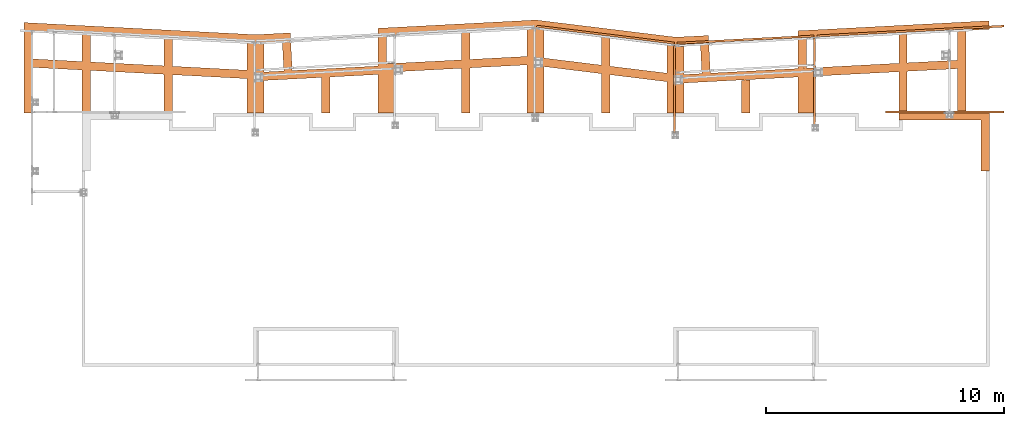
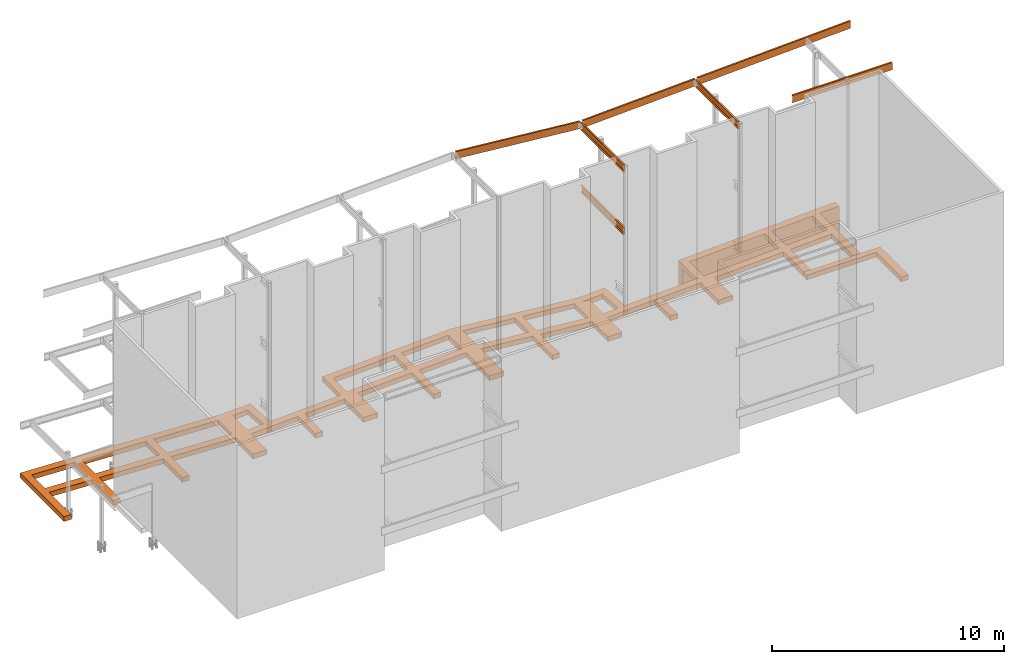
# One storey, part 4 of 89: 9 proxies.
"""IFC4 building model written with IfcOpenShell, lengths in feet."""

from ifc_helpers import new_model, entity, si_unit, converted_unit, derived_unit, direction, frame, frame_2d, origin, origin_2d_with_axis, place, context, subcontext, project, spatial, polyline, rectangle, outline, extrude, source, transform, mapped, material, type_object, type_shapes, element, save


model = new_model("IFC4")

# Units and contexts
model_context = context("Model", 3, precision=0.0001, world=origin(), true_north=direction((6.12303176911189e-17, 1.0)))
body_context = subcontext(model_context, "Body", "Model", "MODEL_VIEW")
ifc_project = project(units=[converted_unit("LENGTHUNIT", "FOOT", entity("IfcRatioMeasure", 0.3048), si_unit("LENGTHUNIT", "METRE"), dimensions=[1, 0, 0, 0, 0, 0, 0]), converted_unit("AREAUNIT", "SQUARE FOOT", entity("IfcRatioMeasure", 0.09290304), si_unit("AREAUNIT", "SQUARE_METRE"), dimensions=[2, 0, 0, 0, 0, 0, 0]), converted_unit("VOLUMEUNIT", "CUBIC FOOT", entity("IfcRatioMeasure", 0.028316846592), si_unit("VOLUMEUNIT", "CUBIC_METRE"), dimensions=[3, 0, 0, 0, 0, 0, 0]), si_unit("PLANEANGLEUNIT", "RADIAN"), si_unit("MASSUNIT", "GRAM", prefix="KILO"), derived_unit("MASSDENSITYUNIT", [(si_unit("MASSUNIT", "GRAM", prefix="KILO"), 1), (si_unit("LENGTHUNIT", "METRE"), -3)]), derived_unit("MOMENTOFINERTIAUNIT", [(si_unit("LENGTHUNIT", "METRE"), 4)]), si_unit("TIMEUNIT", "SECOND"), si_unit("FREQUENCYUNIT", "HERTZ"), si_unit("THERMODYNAMICTEMPERATUREUNIT", "DEGREE_CELSIUS"), derived_unit("THERMALTRANSMITTANCEUNIT", [(si_unit("MASSUNIT", "GRAM", prefix="KILO"), 1), (si_unit("THERMODYNAMICTEMPERATUREUNIT", "KELVIN"), -1), (si_unit("TIMEUNIT", "SECOND"), -3)]), derived_unit("VOLUMETRICFLOWRATEUNIT", [(si_unit("LENGTHUNIT", "METRE"), 3), (si_unit("TIMEUNIT", "SECOND"), -1)]), si_unit("ELECTRICCURRENTUNIT", "AMPERE"), si_unit("ELECTRICVOLTAGEUNIT", "VOLT"), si_unit("POWERUNIT", "WATT"), si_unit("FORCEUNIT", "NEWTON"), si_unit("ILLUMINANCEUNIT", "LUX"), si_unit("LUMINOUSFLUXUNIT", "LUMEN"), si_unit("LUMINOUSINTENSITYUNIT", "CANDELA"), derived_unit("USERDEFINED", [(si_unit("MASSUNIT", "GRAM", prefix="KILO"), -1), (si_unit("LENGTHUNIT", "METRE"), -2), (si_unit("TIMEUNIT", "SECOND"), 3), (si_unit("LUMINOUSFLUXUNIT", "LUMEN"), 1)]), derived_unit("LINEARVELOCITYUNIT", [(si_unit("LENGTHUNIT", "METRE"), 1), (si_unit("TIMEUNIT", "SECOND"), -1)]), si_unit("PRESSUREUNIT", "PASCAL"), derived_unit("USERDEFINED", [(si_unit("LENGTHUNIT", "METRE"), -2), (si_unit("MASSUNIT", "GRAM", prefix="KILO"), 1), (si_unit("TIMEUNIT", "SECOND"), -2)]), derived_unit("LINEARFORCEUNIT", [(si_unit("MASSUNIT", "GRAM", prefix="KILO"), 1), (si_unit("LENGTHUNIT", "METRE"), 1), (si_unit("TIMEUNIT", "SECOND"), -2), (si_unit("LENGTHUNIT", "METRE"), -1)]), derived_unit("PLANARFORCEUNIT", [(si_unit("MASSUNIT", "GRAM", prefix="KILO"), 1), (si_unit("LENGTHUNIT", "METRE"), 1), (si_unit("TIMEUNIT", "SECOND"), -2), (si_unit("LENGTHUNIT", "METRE"), -2)])], contexts=[model_context])

# Site, building, storey
site_placement = place(None, origin())
site = spatial("IfcSite", under=ifc_project, at=site_placement, CompositionType="ELEMENT")
building_placement = place(site_placement, frame((-472.238160486, -49.138065117, 0.0)))
building = spatial("IfcBuilding", under=site, at=building_placement, CompositionType="ELEMENT")
storey_placement = place(building_placement, origin())
storey = spatial("IfcBuildingStorey", under=building, at=storey_placement, Name="Level 1", CompositionType="ELEMENT", Elevation=0.0)

# Proxies
ifc_material_1 = material(Name="Color", Category="Materials")
building_element_proxy_type_1 = type_object("IfcBuildingElementProxyType", Name="M_21", PredefinedType="NOTDEFINED", material=ifc_material_1)
shared_shape_1 = source(origin(), body_context, "Body", "SweptSolid", [
    extrude(outline(polyline([(3.38888888888886, -5.02777777777771), (4.55555555555554, -5.02777777777771), (4.55555555555554, 2.97222222222229), (-7.94444444444446, 2.97222222222229), (-7.94444444444446, 2.05555555555566), (3.38888888888886, 2.05555555555566), (3.38888888888886, -5.02777777777771)])), frame((7.94444444444446, 5.02777777777771, 0.0)), (0.0, 0.0, 1.0), 0.833333333333333),
])
type_shapes(building_element_proxy_type_1, [shared_shape_1])
proxy_1_placement = place(building_placement, frame((319.309225024729, 1000.0, -0.833333333333333)))
element("IfcBuildingElementProxy", 1, at=proxy_1_placement, inside=storey, type_object=building_element_proxy_type_1, material=ifc_material_1, Name="M_21:M_21", ObjectType="M_21:M_21", PredefinedType="NOTDEFINED", context=body_context, shape_type="MappedRepresentation", body=[
    mapped(shared_shape_1, transform((0.0, 0.0, 0.0), scale=1.0)),
])
building_element_proxy_type_2 = type_object("IfcBuildingElementProxyType", Name="e28", PredefinedType="NOTDEFINED", material=ifc_material_1)
shared_shape_2 = source(origin(), body_context, "Body", "SweptSolid", [
    extrude(outline(polyline([(-0.716220445171256, -2.60390514617306), (0.451947401929668, -2.60390514617306), (0.716269587385031, 2.60487355113727), (-0.451996544143557, 2.60293674120885), (-0.716220445171256, -2.60390514617306)])), frame((107.489256819971, 8.79611654616951, 3.33333333333334), z_axis=(0.0, 0.0, 1.0), x_axis=(0.998714927449883, 0.05068030868863, 0.0)), (0.0, 0.0, 1.0), 0.833333333333333),
    extrude(outline(polyline([(-0.583333333333314, -5.48222303152397), (0.583333333333371, -5.48222303152397), (0.583333333333371, 5.51279423610583), (-0.583333333333314, 5.45165182694211), (-0.583333333333314, -5.48222303152397)])), frame((121.405923486638, 5.48222303152409, 3.33333333333334)), (0.0, 0.0, 1.0), 0.833333333333333),
    extrude(outline(polyline([(-1.16666666666663, -2.52509735193451), (1.16666666666669, -2.52509735193451), (1.16666666666669, 2.58623976109823), (-1.16666666666663, 2.46395494277112), (-1.16666666666663, -2.52509735193451)])), frame((108.072590153305, 2.52509735193462, 3.33333333333334)), (0.0, 0.0, 1.0), 0.833333333333333),
    extrude(outline(polyline([(-0.583333333333371, -2.2767293855203), (0.583333333333314, -2.2767293855203), (0.583333333333314, 2.30730059010205), (-0.583333333333371, 2.24615818093855), (-0.583333333333371, -2.2767293855203)])), frame((99.6666666666675, 2.27672938552041, 3.33333333333334)), (0.0, 0.0, 1.0), 0.833333333333333),
    extrude(outline(polyline([(-1.16666666666663, -4.65859764349), (1.16666666666669, -4.65859764349), (1.16666666666669, 4.51534898910336), (-1.16666666666663, 4.80184629787686), (-1.16666666666663, -4.65859764349)])), frame((90.0, 4.65859764349329, 3.33333333333334)), (0.0, 0.0, 1.0), 0.833333333333333),
    extrude(outline(polyline([(-0.583333333333371, -5.25205635452062), (0.583333333333314, -5.25205635452062), (0.583333333333314, 5.18043202732736), (-0.583333333333371, 5.32368068171388), (-0.583333333333371, -5.25205635452062)])), frame((80.3333333333334, 5.25205635452073, 3.33333333333334)), (0.0, 0.0, 1.0), 0.833333333333333),
    extrude(outline(polyline([(-1.16501369037434, -6.9742324147046), (1.16831964295898, -6.9742324147046), (1.16831964295898, 4.57354906201101), (-0.00661190516927945, 4.71781251623895), (-1.16501369037434, 4.65710325115879), (-1.16501369037434, -6.9742324147046)])), frame((70.6650136903744, 6.97423241470472, 3.33333333333334)), (0.0, 0.0, 1.0), 0.833333333333333),
    extrude(outline(polyline([(-0.583333333333314, -5.59293477097879), (0.583333333333371, -5.59293477097879), (0.583333333333371, 5.62350597556065), (-0.583333333333314, 5.56236356639715), (-0.583333333333314, -5.59293477097879)])), frame((61.0, 5.5929347709789, 3.33333333333334)), (0.0, 0.0, 1.0), 0.833333333333333),
    extrude(outline(polyline([(-1.16666666666666, -2.82430670127235), (1.16666666666669, -2.82430670127235), (1.16666666666669, 2.88544911043596), (-1.16666666666666, 2.76316429210874), (-1.16666666666666, -2.82430670127235)])), frame((50.0833333333338, 2.82430670127246, 3.33333333333334)), (0.0, 0.0, 1.0), 0.833333333333333),
    extrude(outline(polyline([(-0.583333333333343, -2.47858575353951), (0.583333333333343, -2.47858575353951), (0.583333333333343, 2.50915695812125), (-0.583333333333343, 2.44801454895764), (-0.583333333333343, -2.47858575353951)])), frame((41.6666666666672, 2.47858575353962, 3.33333333333334)), (0.0, 0.0, 1.0), 0.833333333333333),
    extrude(outline(polyline([(-0.583333333333314, -5.14977697854977), (0.583333333333343, -5.14977697854977), (0.583333333333343, 5.11920577396768), (-0.583333333333314, 5.1803481831314), (-0.583333333333314, -5.14977697854977)])), frame((19.9166666666674, 5.14977697854988, 3.33333333333334)), (0.0, 0.0, 1.0), 0.833333333333333),
    extrude(outline(polyline([(-0.583333333333314, -5.4467543944869), (0.583333333333343, -5.4467543944869), (0.583333333333343, 5.41618318990515), (-0.583333333333314, 5.47732559906865), (-0.583333333333314, -5.4467543944869)])), frame((8.58333333333343, 5.44675439448702, 3.33333333333334)), (0.0, 0.0, 1.0), 0.833333333333333),
    extrude(outline(polyline([(-0.583333333333314, -5.65638551161908), (0.583333333333343, -5.65638551161908), (0.583333333333343, 5.62581430703733), (-0.583333333333314, 5.68695671620083), (-0.583333333333314, -5.65638551161908)])), frame((0.583333333333428, 5.65638551161931, 3.33333333333334)), (0.0, 0.0, 1.0), 0.833333333333333),
    extrude(rectangle(XDim=2.33333333333334, YDim=9.72718635191302, at=frame_2d((1.4210854715202e-14, 5.6843418860808e-14), x_axis=(1.0, 0.0))), frame((32.0, 4.86359317595668, 3.33333333333334), z_axis=(0.0, 0.0, 1.0), x_axis=(-1.0, 0.0, 0.0)), (0.0, 0.0, 1.0), 0.833333333333333),
    extrude(outline(polyline([(-15.9772076249558, -0.583333333333303), (16.0690896334425, -0.583333333333303), (16.007947224279, 0.583333333333353), (-16.0998292327657, 0.58333333333336), (-15.9772076249558, -0.583333333333303)])), frame((16.0165381967659, 6.12294701538076, 3.33333333333334), z_axis=(0.0, 0.0, 1.0), x_axis=(-0.998629534754574, 0.0523359562429452, 0.0)), (0.0, 0.0, 1.0), 0.833333333333333),
    extrude(outline(polyline([(-15.9772076249558, -0.583333333333303), (16.0690896334425, -0.583333333333303), (16.007947224279, 0.583333333333353), (-16.0998292327657, 0.58333333333336), (-15.9772076249558, -0.583333333333303)])), frame((16.0165381967659, 11.0880848976208, 3.33333333333334), z_axis=(0.0, 0.0, 1.0), x_axis=(-0.998629534754574, 0.0523359562429452, 0.0)), (0.0, 0.0, 1.0), 0.833333333333333),
    extrude(rectangle(XDim=4.04166666666675, YDim=1.16666666666663, at=origin_2d_with_axis()), frame((36.371765741045, 7.87155186091172, 3.33333333333334), z_axis=(0.0, 0.0, 1.0), x_axis=(-0.0523359562429114, 0.998629534754576, 0.0)), (0.0, 0.0, 1.0), 0.833333333333333),
    extrude(outline(polyline([(-0.75118366496361, -3.18750000000003), (0.417084072033901, -3.18750000000003), (0.751183664963627, 3.1874999999998), (-0.417084072033879, 3.18749999999991), (-0.75118366496361, -3.18750000000003)])), frame((49.5000000000004, 8.55957346433365, 3.33333333333334), z_axis=(0.0, 0.0, 1.0), x_axis=(0.998629534754571, 0.0523359562429981, 0.0)), (0.0, 0.0, 1.0), 0.833333333333333),
    extrude(rectangle(XDim=1.16666666666658, YDim=16.9375, at=frame_2d((-1.12798659301916e-13, 1.95399252334028e-14), x_axis=(1.0, 0.0))), frame((40.7626352074543, 5.49392709439894, 3.33333333333334), z_axis=(0.0, 0.0, 1.0), x_axis=(0.0523359562429399, -0.998629534754574, 0.0)), (0.0, 0.0, 1.0), 0.833333333333332),
    extrude(rectangle(XDim=1.16666666666658, YDim=4.79166666666666, at=origin_2d_with_axis()), frame((34.4254581565856, 10.3772906869754, 3.33333333333334), z_axis=(0.0, 0.0, 1.0), x_axis=(0.0523359562429399, -0.998629534754574, 0.0)), (0.0, 0.0, 1.0), 0.833333333333332),
    extrude(outline(polyline([(-0.583333333333419, -10.8548212972934), (0.58333333333316, -10.8548212972934), (0.583333333333651, 10.75196389188), (-0.583333333332941, 10.9576787027067), (-0.583333333333419, -10.8548212972934)])), frame((60.0466402328066, 6.75490205995686, 3.33333333333334), z_axis=(0.0, 0.0, 1.0), x_axis=(0.0523359562429642, -0.998629534754573, 0.0)), (0.0, 0.0, 1.0), 0.833333333333333),
    extrude(outline(polyline([(-0.583333333333532, -10.8548212972934), (0.583333333333046, -10.8548212972934), (0.583333333333537, 10.75196389188), (-0.583333333333054, 10.9576787027067), (-0.583333333333532, -10.8548212972934)])), frame((59.7871411164356, 11.7064401697868, 3.33333333333334), z_axis=(0.0, 0.0, 1.0), x_axis=(0.0523359562429642, -0.998629534754573, 0.0)), (0.0, 0.0, 1.0), 0.833333333333333),
    extrude(outline(polyline([(-2.3703465208095, -10.0836203478316), (-1.18568214027603, -10.0836203478316), (2.35248551979985, 9.98232557752598), (1.20354314128558, 10.1849151181373), (-2.3703465208095, -10.0836203478316)])), frame((80.1715356243377, 5.99018475512946, 3.33333333333334), z_axis=(0.0, 0.0, 1.0), x_axis=(-0.0523359562428645, 0.998629534754578, 0.0)), (0.0, 0.0, 1.0), 0.833333333333333),
    extrude(outline(polyline([(-2.29252358783975, -9.64226456292806), (-1.10785920730628, -9.64226456292805), (2.2746625868302, 9.54096979262238), (1.12572020831583, 9.74355933323378), (-2.29252358783975, -9.64226456292806)])), frame((80.3462142602267, 11.0902451949404, 3.33333333333334), z_axis=(0.0, 0.0, 1.0), x_axis=(-0.0523359562429123, 0.998629534754576, 0.0)), (0.0, 0.0, 1.0), 0.833333333333332),
    extrude(outline(polyline([(0.722222222222372, -3.08333333333344), (1.88888888888901, -3.08333333333344), (1.88888888888883, 2.12500000000035), (-2.61111111111117, 2.12500000000046), (-2.61111111111115, 0.958333333333084), (0.722222222222231, 0.958333333333207), (0.722222222222372, -3.08333333333344)])), frame((92.7519918867791, 8.50310864192022, 3.33333333333334), z_axis=(0.0, 0.0, 1.0), x_axis=(0.998629534754576, 0.052335956242913, 0.0)), (0.0, 0.0, 1.0), 0.833333333333333),
    extrude(rectangle(XDim=38.7188758217334, YDim=1.16666666666669, at=origin_2d_with_axis()), frame((109.627654629013, 5.71582604818479, 3.33333333333334), z_axis=(0.0, 0.0, 1.0), x_axis=(-0.998629534754574, -0.0523359562429475, 0.0)), (0.0, 0.0, 1.0), 0.833333333333333),
    extrude(outline(polyline([(-5.69466953758479, -0.583333333333314), (5.72524074216642, -0.583333333333314), (5.66409833300281, 0.583333333333371), (-5.69466953758479, 0.583333333333371), (-5.69466953758479, -0.583333333333314)])), frame((129.513365128576, 5.6946695375849, 3.33333333333334), z_axis=(0.0, 0.0, 1.0), x_axis=(0.0, 1.0, 0.0)), (0.0, 0.0, 1.0), 0.833333333333333),
    extrude(rectangle(XDim=26.4114583333333, YDim=1.16666666666658, at=origin_2d_with_axis()), frame((120.12408396825, 11.4814015689964, 0.0), z_axis=(0.0, 0.0, 1.0), x_axis=(-0.998629534754574, -0.0523359562429439, 0.0)), (0.0, 0.0, 1.0), 4.16666666666667),
])
type_shapes(building_element_proxy_type_2, [shared_shape_2])
proxy_2_placement = place(building_placement, frame((198.486634871424, 1008.0, -4.16666666666667)))
element("IfcBuildingElementProxy", 2, at=proxy_2_placement, inside=storey, type_object=building_element_proxy_type_2, material=ifc_material_1, Name="e28:e28", ObjectType="e28:e28", PredefinedType="NOTDEFINED", context=body_context, shape_type="MappedRepresentation", body=[
    mapped(shared_shape_2, transform((0.0, 0.0, 0.0), scale=1.0)),
])
ifc_material_2 = material(Name="Color 7720", Category="Materials")
building_element_proxy_type_3 = type_object("IfcBuildingElementProxyType", Name="BEAM 9688:BEAM 9688", PredefinedType="NOTDEFINED", material=ifc_material_2)
shared_shape_3 = source(origin(), body_context, "Body", "SweptSolid", [
    extrude(outline(polyline([(-0.625, -0.10250487228124), (0.625, -0.10250487228124), (0.625, 0.180828461052064), (0.59166594419212, 0.180828461052064), (0.557364297421448, -0.0249885570546364), (0.551184769668311, -0.0424107340231028), (0.539385739901633, -0.0566410435819763), (0.523409352768051, -0.0659401762152361), (0.505208333333333, -0.0691715389479361), (-0.505208333333333, -0.0691715389479361), (-0.523409352768051, -0.0659401762152361), (-0.539385739901633, -0.0566410435819763), (-0.551184769668311, -0.0424107340231028), (-0.557364297421448, -0.0249885570546364), (-0.59166594419212, 0.180828461052064), (-0.625, 0.180828461052064), (-0.625, -0.10250487228124)])), frame((0.0, -0.625, -0.10250487228124), z_axis=(1.0, 0.0, 0.0), x_axis=(0.0, -1.0, 0.0)), (0.0, 0.0, 1.0), 16.3333333333333),
])
type_shapes(building_element_proxy_type_3, [shared_shape_3])
proxy_3_placement = place(building_placement, frame((317.5, 1008.04166666667, 31.0833333333333), z_axis=(0.0, -1.0, 0.0), x_axis=(1.0, 0.0, 0.0)))
element("IfcBuildingElementProxy", 3, at=proxy_3_placement, inside=storey, type_object=building_element_proxy_type_3, material=ifc_material_2, Name="c731", ObjectType="BEAM", PredefinedType="NOTDEFINED", context=body_context, shape_type="MappedRepresentation", body=[
    mapped(shared_shape_3, transform((0.0, 0.0, 0.0), scale=1.0)),
])
building_element_proxy_type_4 = type_object("IfcBuildingElementProxyType", Name="BEAM 9649:BEAM 9649", PredefinedType="NOTDEFINED", material=ifc_material_2)
shared_shape_4 = source(origin(), body_context, "Body", "SweptSolid", [
    extrude(outline(polyline([(-0.625, -0.102504872281253), (0.625, -0.102504872281253), (0.625, 0.180828461052087), (0.59166594419212, 0.180828461052087), (0.557364297421448, -0.0249885570546883), (0.551184769668311, -0.0424107340231546), (0.539385739901633, -0.0566410435819523), (0.523409352768051, -0.0659401762152121), (0.505208333333333, -0.0691715389479131), (-0.505208333333333, -0.0691715389479131), (-0.523409352768051, -0.0659401762152121), (-0.539385739901633, -0.0566410435819523), (-0.551184769668311, -0.0424107340231546), (-0.557364297421448, -0.0249885570546883), (-0.59166594419212, 0.180828461052087), (-0.625, 0.180828461052087), (-0.625, -0.102504872281253)])), frame((0.0, 0.625, 0.180828461052087), z_axis=(1.0, 0.0, 0.0), x_axis=(0.0, -1.0, 0.0)), (0.0, 0.0, 1.0), 12.100194730959),
])
type_shapes(building_element_proxy_type_4, [shared_shape_4])
proxy_4_placement = place(building_placement, frame((288.216666666667, 1005.234375, 29.8333333333333), z_axis=(1.0, 0.0, 0.0), x_axis=(0.0, 1.0, 0.0)))
element("IfcBuildingElementProxy", 4, at=proxy_4_placement, inside=storey, type_object=building_element_proxy_type_4, material=ifc_material_2, Name="c766", ObjectType="BEAM", PredefinedType="NOTDEFINED", context=body_context, shape_type="MappedRepresentation", body=[
    mapped(shared_shape_4, transform((0.0, 0.0, 0.0), scale=1.0)),
])
building_element_proxy_type_5 = type_object("IfcBuildingElementProxyType", Name="BEAM 9643:BEAM 9643", PredefinedType="NOTDEFINED", material=ifc_material_2)
shared_shape_5 = source(origin(), body_context, "Body", "SweptSolid", [
    extrude(outline(polyline([(-0.625, -0.102504872281253), (0.625, -0.102504872281253), (0.625, 0.180828461052087), (0.59166594419212, 0.180828461052087), (0.557364297421448, -0.0249885570546883), (0.551184769668311, -0.0424107340231546), (0.539385739901633, -0.0566410435819523), (0.523409352768051, -0.0659401762152121), (0.505208333333333, -0.0691715389479131), (-0.505208333333333, -0.0691715389479131), (-0.523409352768051, -0.0659401762152121), (-0.539385739901633, -0.0566410435819523), (-0.551184769668311, -0.0424107340231546), (-0.557364297421448, -0.0249885570546883), (-0.59166594419212, 0.180828461052087), (-0.625, 0.180828461052087), (-0.625, -0.102504872281253)])), frame((0.0, 0.625, 0.180828461052087), z_axis=(1.0, 0.0, 0.0), x_axis=(0.0, -1.0, 0.0)), (0.0, 0.0, 1.0), 12.0952401992555),
])
type_shapes(building_element_proxy_type_5, [shared_shape_5])
proxy_5_placement = place(building_placement, frame((307.55, 1006.25, 29.8333333333333), z_axis=(1.0, 0.0, 0.0), x_axis=(0.0, 1.0, 0.0)))
element("IfcBuildingElementProxy", 5, at=proxy_5_placement, inside=storey, type_object=building_element_proxy_type_5, material=ifc_material_2, Name="c771", ObjectType="BEAM", PredefinedType="NOTDEFINED", context=body_context, shape_type="MappedRepresentation", body=[
    mapped(shared_shape_5, transform((0.0, 0.0, 0.0), scale=1.0)),
])
building_element_proxy_type_6 = type_object("IfcBuildingElementProxyType", Name="BEAM 9615:BEAM 9615", PredefinedType="NOTDEFINED", material=ifc_material_2)
shared_shape_6 = source(origin(), body_context, "Body", "SweptSolid", [
    extrude(outline(polyline([(-0.625, -0.102504872281253), (0.625, -0.102504872281253), (0.625, 0.180828461052087), (0.59166594419212, 0.180828461052087), (0.557364297421448, -0.0249885570546883), (0.551184769668311, -0.0424107340231546), (0.539385739901635, -0.0566410435819523), (0.523409352768051, -0.0659401762152121), (0.505208333333333, -0.0691715389479131), (-0.505208333333333, -0.0691715389479131), (-0.523409352768051, -0.0659401762152121), (-0.539385739901635, -0.0566410435819523), (-0.551184769668311, -0.0424107340231546), (-0.557364297421448, -0.0249885570546883), (-0.59166594419212, 0.180828461052087), (-0.625, 0.180828461052087), (-0.625, -0.102504872281253)])), frame((0.0, 0.625, 0.180828461052087), z_axis=(1.0, 0.0, 0.0), x_axis=(0.0, -1.0, 0.0)), (0.0, 0.0, 1.0), 12.0684540033702),
])
type_shapes(building_element_proxy_type_6, [shared_shape_6])
proxy_6_placement = place(building_placement, frame((288.216666666667, 1005.234375, 19.0208333333333), z_axis=(1.0, 0.0, 0.0), x_axis=(0.0, 1.0, 0.0)))
element("IfcBuildingElementProxy", 6, at=proxy_6_placement, inside=storey, type_object=building_element_proxy_type_6, material=ifc_material_2, Name="c756", ObjectType="BEAM", PredefinedType="NOTDEFINED", context=body_context, shape_type="MappedRepresentation", body=[
    mapped(shared_shape_6, transform((0.0, 0.0, 0.0), scale=1.0)),
])
building_element_proxy_type_7 = type_object("IfcBuildingElementProxyType", Name="BEAM 9698:BEAM 9698", PredefinedType="NOTDEFINED", material=ifc_material_2)
shared_shape_7 = source(origin(), body_context, "Body", "SweptSolid", [
    extrude(outline(polyline([(-0.625, -0.102504872281196), (0.625, -0.102504872281196), (0.625, 0.180828461052094), (0.59166594419212, 0.180828461052094), (0.557364297421448, -0.0249885570546143), (0.551184769668311, -0.042410734023135), (0.539385739901633, -0.0566410435820184), (0.523409352768051, -0.0659401762152877), (0.505208333333333, -0.0691715389479377), (-0.505208333333333, -0.0691715389479377), (-0.523409352768051, -0.0659401762152877), (-0.539385739901633, -0.0566410435820184), (-0.551184769668311, -0.042410734023135), (-0.557364297421448, -0.0249885570546143), (-0.59166594419212, 0.180828461052094), (-0.625, 0.180828461052094), (-0.625, -0.102504872281196)])), frame((0.0, 0.625, 0.180828461052094), z_axis=(1.0, 0.0, 0.0), x_axis=(0.0, -1.0, 0.0)), (0.0, 0.0, 1.0), 18.9640320226265),
])
type_shapes(building_element_proxy_type_7, [shared_shape_7])
proxy_7_placement = place(building_placement, frame((288.682816907818, 1017.7943899411, 29.8333333333333), z_axis=(0.0523359562429427, -0.998629534754574, 0.0), x_axis=(0.998629534754574, 0.0523359562429427, 0.0)))
element("IfcBuildingElementProxy", 7, at=proxy_7_placement, inside=storey, type_object=building_element_proxy_type_7, material=ifc_material_2, Name="62B1", ObjectType="BEAM", PredefinedType="NOTDEFINED", context=body_context, shape_type="MappedRepresentation", body=[
    mapped(shared_shape_7, transform((0.0, 0.0, 0.0), scale=1.0)),
])
building_element_proxy_type_8 = type_object("IfcBuildingElementProxyType", Name="BEAM 9645:BEAM 9645", PredefinedType="NOTDEFINED", material=ifc_material_2)
shared_shape_8 = source(origin(), body_context, "Body", "SweptSolid", [
    extrude(outline(polyline([(-0.625, -0.102504872281364), (0.625, -0.102504872281364), (0.625, 0.180828461052066), (0.59166594419212, 0.180828461052066), (0.557364297421448, -0.0249885570545866), (0.551184769668311, -0.0424107340231456), (0.539385739901633, -0.0566410435819424), (0.523409352768051, -0.06594017621515), (0.505208333333333, -0.069171538947943), (-0.505208333333333, -0.069171538947943), (-0.523409352768051, -0.06594017621515), (-0.539385739901633, -0.0566410435819424), (-0.551184769668311, -0.0424107340231456), (-0.557364297421448, -0.0249885570545867), (-0.59166594419212, 0.180828461052066), (-0.625, 0.180828461052066), (-0.625, -0.102504872281364)])), frame((0.0, 0.625, 0.180828461052066), z_axis=(1.0, 0.0, 0.0), x_axis=(0.0, -1.0, 0.0)), (0.0, 0.0, 1.0), 19.15625),
])
type_shapes(building_element_proxy_type_8, [shared_shape_8])
proxy_8_placement = place(building_placement, frame((269.325264582967, 1020.1409877417, 29.8333333333333), z_axis=(-0.121869343405146, -0.992546151641322, 0.0), x_axis=(0.992546151641322, -0.121869343405146, 0.0)))
element("IfcBuildingElementProxy", 8, at=proxy_8_placement, inside=storey, type_object=building_element_proxy_type_8, material=ifc_material_2, Name="59B1", ObjectType="BEAM", PredefinedType="NOTDEFINED", context=body_context, shape_type="MappedRepresentation", body=[
    mapped(shared_shape_8, transform((0.0, 0.0, 0.0), scale=1.0)),
])
building_element_proxy_type_9 = type_object("IfcBuildingElementProxyType", Name="BEAM 9635:BEAM 9635", PredefinedType="NOTDEFINED", material=ifc_material_2)
shared_shape_9 = source(origin(), body_context, "Body", "SweptSolid", [
    extrude(outline(polyline([(-0.625, -0.102504872281254), (0.625, -0.102504872281254), (0.625, 0.18082846105208), (0.591665944192121, 0.18082846105208), (0.557364297421449, -0.024988557054672), (0.551184769668311, -0.0424107340231663), (0.539385739901635, -0.0566410435819367), (0.523409352768051, -0.0659401762152093), (0.505208333333333, -0.0691715389479203), (-0.505208333333333, -0.0691715389479203), (-0.523409352768051, -0.0659401762152093), (-0.539385739901635, -0.0566410435819367), (-0.551184769668311, -0.0424107340231663), (-0.557364297421449, -0.024988557054672), (-0.591665944192121, 0.18082846105208), (-0.625, 0.18082846105208), (-0.625, -0.102504872281254)])), frame((0.0, 0.625, 0.18082846105208), z_axis=(1.0, 0.0, 0.0), x_axis=(0.0, -1.0, 0.0)), (0.0, 0.0, 1.0), 25.8533964769148),
])
type_shapes(building_element_proxy_type_9, [shared_shape_9])
proxy_9_placement = place(building_placement, frame((308.005747850164, 1018.8048828081, 29.8333333333333), z_axis=(0.0523359562429399, -0.998629534754574, 0.0), x_axis=(0.998629534754574, 0.0523359562429399, 0.0)))
element("IfcBuildingElementProxy", 9, at=proxy_9_placement, inside=storey, type_object=building_element_proxy_type_9, material=ifc_material_2, Name="47B1", ObjectType="BEAM", PredefinedType="NOTDEFINED", context=body_context, shape_type="MappedRepresentation", body=[
    mapped(shared_shape_9, transform((0.0, 0.0, 0.0), scale=1.0)),
])

save(model, "model.ifc")
